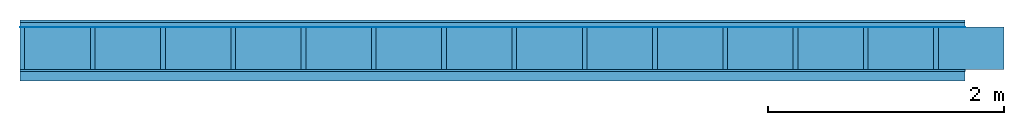
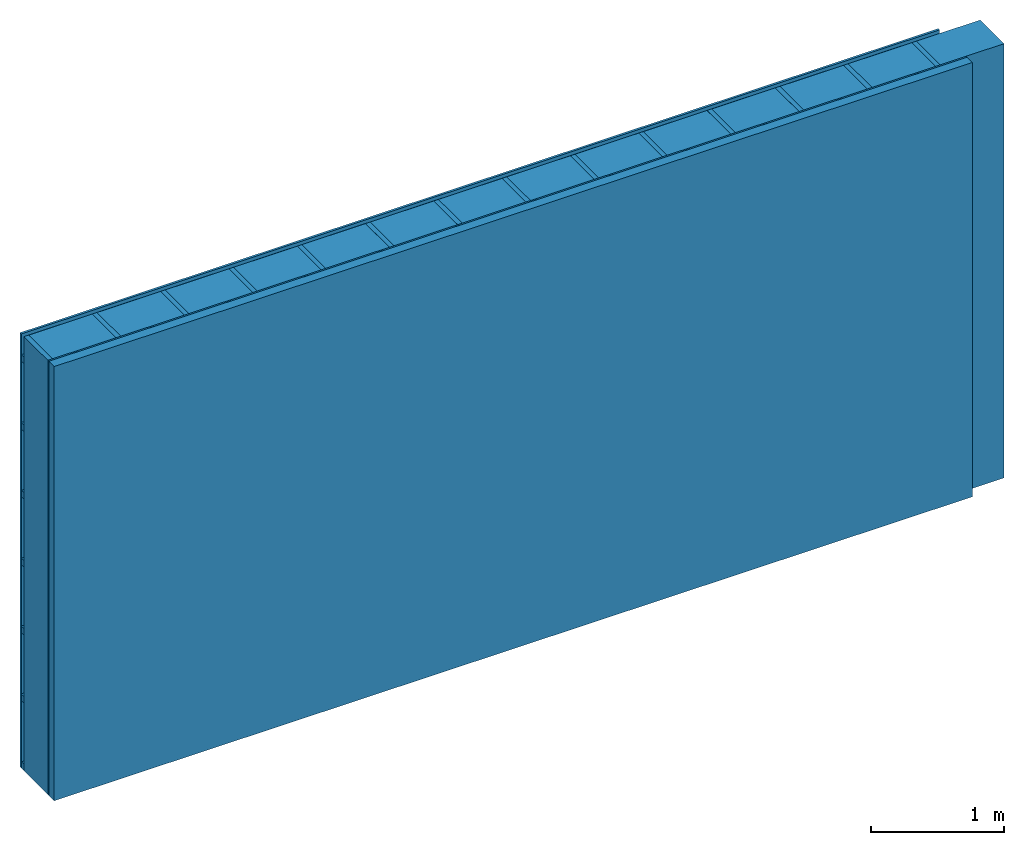
# One storey: 4 plates, 3 members, 1 element without a shape of its own.
"""IFC4 building model written with IfcOpenShell, lengths in metres."""

from ifc_helpers import new_model, si_unit, derived_unit, direction, frame, frame_2d, origin, origin_with_axes, place, context, project, spatial, rectangle, extrude, material, layer, layer_set, type_object, element, aggregate, save


model = new_model("IFC4")

# Units and contexts
plan_context = context("Plan", 3, precision=1e-05, world=origin(), true_north=direction((0.0, 1.0)))
model_context = context("Model", 3, precision=1e-05, world=origin(), true_north=direction((0.0, 1.0)))
ifc_project = project(units=[si_unit("LENGTHUNIT", "METRE"), derived_unit("SOUNDPRESSUREUNIT", [(si_unit("PRESSUREUNIT", "PASCAL", prefix="MICRO"), 0)]), si_unit("ENERGYUNIT", "JOULE", prefix="MEGA"), si_unit("MASSUNIT", "GRAM", prefix="KILO"), derived_unit("THERMALTRANSMITTANCEUNIT", [(si_unit("POWERUNIT", "WATT"), 1), (si_unit("AREAUNIT", "SQUARE_METRE"), -1), (si_unit("THERMODYNAMICTEMPERATUREUNIT", "KELVIN"), -1)]), derived_unit("AREADENSITYUNIT", [(si_unit("MASSUNIT", "GRAM", prefix="KILO"), 1), (si_unit("AREAUNIT", "SQUARE_METRE"), -1)]), derived_unit("USERDEFINED", [(si_unit("ENERGYUNIT", "JOULE", prefix="MEGA"), 1), (si_unit("AREAUNIT", "SQUARE_METRE"), -1)])], contexts=[plan_context, model_context])

# Site, building, storey
site = spatial("IfcSite", under=ifc_project)
building_placement = place(None, origin())
building = spatial("IfcBuilding", under=site, at=building_placement)
storey_placement = place(building_placement, origin())
storey = spatial("IfcBuildingStorey", under=building, at=storey_placement)

# Wall, members, plates
ifc_material_1 = material(Name="Wood cladding horizontal, closed")
ifc_layer_1 = layer(ifc_material_1, 0.02, Name="Cover 1st layer")
ifc_layer_2 = layer(None, 0.04, Name="Battens / profiles (ventilation)")
ifc_material_2 = material(Name="Vapor-permeable water barrier", Category="09.006")
ifc_layer_3 = layer(ifc_material_2, 0.0005, Name="outside 1st layer")
ifc_material_3 = material(Name="of the art")
ifc_layer_4 = layer(ifc_material_3, 0.0, Name="Bond")
ifc_layer_5 = layer(None, 0.36, Name="Support")
ifc_layer_6 = layer(ifc_material_3, 0.0, Name="Bond")
ifc_material_4 = material(Name="OSB panel", Category="07.013")
ifc_layer_7 = layer(ifc_material_4, 0.015, Name="1st layer")
ifc_material_5 = material(Name="Solid timber panel")
ifc_layer_8 = layer(ifc_material_5, 0.08, Name="Covering 1st layer")
ifc_layer_set = layer_set([ifc_layer_1, ifc_layer_2, ifc_layer_3, ifc_layer_4, ifc_layer_5, ifc_layer_6, ifc_layer_7, ifc_layer_8])
wall_type = type_object("IfcWallType", Name="D0963", PredefinedType="NOTDEFINED", material=ifc_layer_set)
wall_placement = place(None, frame((0.0, 0.0, 0.0), z_axis=(0.0, -1.0, 0.0), x_axis=(1.0, 0.0, 0.0)))
wall = element("IfcWall", 1, at=wall_placement, inside=storey, type_object=wall_type, material=ifc_layer_set, Name="Wall #1")
ifc_material_6 = material()
member_1_placement = place(wall_placement, origin())
member_1 = element("IfcMember", 2, at=member_1_placement, material=ifc_material_6, Name="Battens / profiles (ventilation)", context=plan_context, shape_type="SweptSolid", body=[
    extrude(rectangle(XDim=0.06, YDim=0.04, at=frame_2d((0.03, 0.02), x_axis=(1.0, 0.0))), frame((0.0, 0.0, 0.02), z_axis=(1.0, 0.0, 0.0), x_axis=(0.0, 1.0, 0.0)), (0.0, 0.0, 1.0), 8.0),
    extrude(rectangle(XDim=0.06, YDim=0.04, at=frame_2d((0.03, 0.02), x_axis=(1.0, 0.0))), frame((0.0, 0.625, 0.02), z_axis=(1.0, 0.0, 0.0), x_axis=(0.0, 1.0, 0.0)), (0.0, 0.0, 1.0), 8.0),
    extrude(rectangle(XDim=0.06, YDim=0.04, at=frame_2d((0.03, 0.02), x_axis=(1.0, 0.0))), frame((0.0, 1.25, 0.02), z_axis=(1.0, 0.0, 0.0), x_axis=(0.0, 1.0, 0.0)), (0.0, 0.0, 1.0), 8.0),
    extrude(rectangle(XDim=0.06, YDim=0.04, at=frame_2d((0.03, 0.02), x_axis=(1.0, 0.0))), frame((0.0, 1.875, 0.02), z_axis=(1.0, 0.0, 0.0), x_axis=(0.0, 1.0, 0.0)), (0.0, 0.0, 1.0), 8.0),
    extrude(rectangle(XDim=0.06, YDim=0.04, at=frame_2d((0.03, 0.02), x_axis=(1.0, 0.0))), frame((0.0, 2.5, 0.02), z_axis=(1.0, 0.0, 0.0), x_axis=(0.0, 1.0, 0.0)), (0.0, 0.0, 1.0), 8.0),
    extrude(rectangle(XDim=0.06, YDim=0.04, at=frame_2d((0.03, 0.02), x_axis=(1.0, 0.0))), frame((0.0, 3.125, 0.02), z_axis=(1.0, 0.0, 0.0), x_axis=(0.0, 1.0, 0.0)), (0.0, 0.0, 1.0), 8.0),
    extrude(rectangle(XDim=0.06, YDim=0.04, at=frame_2d((0.03, 0.02), x_axis=(1.0, 0.0))), frame((0.0, 3.75, 0.02), z_axis=(1.0, 0.0, 0.0), x_axis=(0.0, 1.0, 0.0)), (0.0, 0.0, 1.0), 8.0),
])
ifc_material_7 = material()
member_2_placement = place(wall_placement, origin())
member_2 = element("IfcMember", 3, at=member_2_placement, material=ifc_material_7, Name="Support", context=plan_context, shape_type="SweptSolid", body=[
    extrude(rectangle(XDim=0.04, YDim=0.36, at=frame_2d((0.02, 0.18), x_axis=(1.0, 0.0))), frame((0.0, 4.0, 0.0605), z_axis=(0.0, -1.0, 0.0), x_axis=(1.0, 0.0, 0.0)), (0.0, 0.0, 1.0), 4.0),
    extrude(rectangle(XDim=0.04, YDim=0.36, at=frame_2d((0.02, 0.18), x_axis=(1.0, 0.0))), frame((0.595, 4.0, 0.0605), z_axis=(0.0, -1.0, 0.0), x_axis=(1.0, 0.0, 0.0)), (0.0, 0.0, 1.0), 4.0),
    extrude(rectangle(XDim=0.04, YDim=0.36, at=frame_2d((0.02, 0.18), x_axis=(1.0, 0.0))), frame((1.19, 4.0, 0.0605), z_axis=(0.0, -1.0, 0.0), x_axis=(1.0, 0.0, 0.0)), (0.0, 0.0, 1.0), 4.0),
    extrude(rectangle(XDim=0.04, YDim=0.36, at=frame_2d((0.02, 0.18), x_axis=(1.0, 0.0))), frame((1.785, 4.0, 0.0605), z_axis=(0.0, -1.0, 0.0), x_axis=(1.0, 0.0, 0.0)), (0.0, 0.0, 1.0), 4.0),
    extrude(rectangle(XDim=0.04, YDim=0.36, at=frame_2d((0.02, 0.18), x_axis=(1.0, 0.0))), frame((2.38, 4.0, 0.0605), z_axis=(0.0, -1.0, 0.0), x_axis=(1.0, 0.0, 0.0)), (0.0, 0.0, 1.0), 4.0),
    extrude(rectangle(XDim=0.04, YDim=0.36, at=frame_2d((0.02, 0.18), x_axis=(1.0, 0.0))), frame((2.975, 4.0, 0.0605), z_axis=(0.0, -1.0, 0.0), x_axis=(1.0, 0.0, 0.0)), (0.0, 0.0, 1.0), 4.0),
    extrude(rectangle(XDim=0.04, YDim=0.36, at=frame_2d((0.02, 0.18), x_axis=(1.0, 0.0))), frame((3.57, 4.0, 0.0605), z_axis=(0.0, -1.0, 0.0), x_axis=(1.0, 0.0, 0.0)), (0.0, 0.0, 1.0), 4.0),
    extrude(rectangle(XDim=0.04, YDim=0.36, at=frame_2d((0.02, 0.18), x_axis=(1.0, 0.0))), frame((4.165, 4.0, 0.0605), z_axis=(0.0, -1.0, 0.0), x_axis=(1.0, 0.0, 0.0)), (0.0, 0.0, 1.0), 4.0),
    extrude(rectangle(XDim=0.04, YDim=0.36, at=frame_2d((0.02, 0.18), x_axis=(1.0, 0.0))), frame((4.76, 4.0, 0.0605), z_axis=(0.0, -1.0, 0.0), x_axis=(1.0, 0.0, 0.0)), (0.0, 0.0, 1.0), 4.0),
    extrude(rectangle(XDim=0.04, YDim=0.36, at=frame_2d((0.02, 0.18), x_axis=(1.0, 0.0))), frame((5.355, 4.0, 0.0605), z_axis=(0.0, -1.0, 0.0), x_axis=(1.0, 0.0, 0.0)), (0.0, 0.0, 1.0), 4.0),
    extrude(rectangle(XDim=0.04, YDim=0.36, at=frame_2d((0.02, 0.18), x_axis=(1.0, 0.0))), frame((5.95, 4.0, 0.0605), z_axis=(0.0, -1.0, 0.0), x_axis=(1.0, 0.0, 0.0)), (0.0, 0.0, 1.0), 4.0),
    extrude(rectangle(XDim=0.04, YDim=0.36, at=frame_2d((0.02, 0.18), x_axis=(1.0, 0.0))), frame((6.545, 4.0, 0.0605), z_axis=(0.0, -1.0, 0.0), x_axis=(1.0, 0.0, 0.0)), (0.0, 0.0, 1.0), 4.0),
    extrude(rectangle(XDim=0.04, YDim=0.36, at=frame_2d((0.02, 0.18), x_axis=(1.0, 0.0))), frame((7.14, 4.0, 0.0605), z_axis=(0.0, -1.0, 0.0), x_axis=(1.0, 0.0, 0.0)), (0.0, 0.0, 1.0), 4.0),
    extrude(rectangle(XDim=0.04, YDim=0.36, at=frame_2d((0.02, 0.18), x_axis=(1.0, 0.0))), frame((7.735, 4.0, 0.0605), z_axis=(0.0, -1.0, 0.0), x_axis=(1.0, 0.0, 0.0)), (0.0, 0.0, 1.0), 4.0),
])
ifc_material_8 = material(Name="Mineral wool")
member_3_placement = place(wall_placement, origin())
member_3 = element("IfcMember", 4, at=member_3_placement, material=ifc_material_8, Name="Cavity", context=plan_context, shape_type="SweptSolid", body=[
    extrude(rectangle(XDim=0.555, YDim=0.36, at=frame_2d((0.2775, 0.18), x_axis=(1.0, 0.0))), frame((0.04, 4.0, 0.0605), z_axis=(0.0, -1.0, 0.0), x_axis=(1.0, 0.0, 0.0)), (0.0, 0.0, 1.0), 4.0),
    extrude(rectangle(XDim=0.555, YDim=0.36, at=frame_2d((0.2775, 0.18), x_axis=(1.0, 0.0))), frame((0.635, 4.0, 0.0605), z_axis=(0.0, -1.0, 0.0), x_axis=(1.0, 0.0, 0.0)), (0.0, 0.0, 1.0), 4.0),
    extrude(rectangle(XDim=0.555, YDim=0.36, at=frame_2d((0.2775, 0.18), x_axis=(1.0, 0.0))), frame((1.23, 4.0, 0.0605), z_axis=(0.0, -1.0, 0.0), x_axis=(1.0, 0.0, 0.0)), (0.0, 0.0, 1.0), 4.0),
    extrude(rectangle(XDim=0.555, YDim=0.36, at=frame_2d((0.2775, 0.18), x_axis=(1.0, 0.0))), frame((1.825, 4.0, 0.0605), z_axis=(0.0, -1.0, 0.0), x_axis=(1.0, 0.0, 0.0)), (0.0, 0.0, 1.0), 4.0),
    extrude(rectangle(XDim=0.555, YDim=0.36, at=frame_2d((0.2775, 0.18), x_axis=(1.0, 0.0))), frame((2.42, 4.0, 0.0605), z_axis=(0.0, -1.0, 0.0), x_axis=(1.0, 0.0, 0.0)), (0.0, 0.0, 1.0), 4.0),
    extrude(rectangle(XDim=0.555, YDim=0.36, at=frame_2d((0.2775, 0.18), x_axis=(1.0, 0.0))), frame((3.015, 4.0, 0.0605), z_axis=(0.0, -1.0, 0.0), x_axis=(1.0, 0.0, 0.0)), (0.0, 0.0, 1.0), 4.0),
    extrude(rectangle(XDim=0.555, YDim=0.36, at=frame_2d((0.2775, 0.18), x_axis=(1.0, 0.0))), frame((3.61, 4.0, 0.0605), z_axis=(0.0, -1.0, 0.0), x_axis=(1.0, 0.0, 0.0)), (0.0, 0.0, 1.0), 4.0),
    extrude(rectangle(XDim=0.555, YDim=0.36, at=frame_2d((0.2775, 0.18), x_axis=(1.0, 0.0))), frame((4.205, 4.0, 0.0605), z_axis=(0.0, -1.0, 0.0), x_axis=(1.0, 0.0, 0.0)), (0.0, 0.0, 1.0), 4.0),
    extrude(rectangle(XDim=0.555, YDim=0.36, at=frame_2d((0.2775, 0.18), x_axis=(1.0, 0.0))), frame((4.8, 4.0, 0.0605), z_axis=(0.0, -1.0, 0.0), x_axis=(1.0, 0.0, 0.0)), (0.0, 0.0, 1.0), 4.0),
    extrude(rectangle(XDim=0.555, YDim=0.36, at=frame_2d((0.2775, 0.18), x_axis=(1.0, 0.0))), frame((5.395, 4.0, 0.0605), z_axis=(0.0, -1.0, 0.0), x_axis=(1.0, 0.0, 0.0)), (0.0, 0.0, 1.0), 4.0),
    extrude(rectangle(XDim=0.555, YDim=0.36, at=frame_2d((0.2775, 0.18), x_axis=(1.0, 0.0))), frame((5.99, 4.0, 0.0605), z_axis=(0.0, -1.0, 0.0), x_axis=(1.0, 0.0, 0.0)), (0.0, 0.0, 1.0), 4.0),
    extrude(rectangle(XDim=0.555, YDim=0.36, at=frame_2d((0.2775, 0.18), x_axis=(1.0, 0.0))), frame((6.585, 4.0, 0.0605), z_axis=(0.0, -1.0, 0.0), x_axis=(1.0, 0.0, 0.0)), (0.0, 0.0, 1.0), 4.0),
    extrude(rectangle(XDim=0.555, YDim=0.36, at=frame_2d((0.2775, 0.18), x_axis=(1.0, 0.0))), frame((7.18, 4.0, 0.0605), z_axis=(0.0, -1.0, 0.0), x_axis=(1.0, 0.0, 0.0)), (0.0, 0.0, 1.0), 4.0),
    extrude(rectangle(XDim=0.555, YDim=0.36, at=frame_2d((0.2775, 0.18), x_axis=(1.0, 0.0))), frame((7.775, 4.0, 0.0605), z_axis=(0.0, -1.0, 0.0), x_axis=(1.0, 0.0, 0.0)), (0.0, 0.0, 1.0), 4.0),
])
plate_1_placement = place(wall_placement, origin())
plate_1 = element("IfcPlate", 5, at=plate_1_placement, material=ifc_material_1, Name="Cover 1st layer", context=plan_context, shape_type="SweptSolid", body=[
    extrude(rectangle(XDim=8.0, YDim=4.0, at=frame_2d((4.0, 2.0), x_axis=(1.0, 0.0))), origin_with_axes(), (0.0, 0.0, 1.0), 0.02),
])
plate_2_placement = place(wall_placement, origin())
plate_2 = element("IfcPlate", 6, at=plate_2_placement, material=ifc_material_2, Name="outside 1st layer", context=plan_context, shape_type="SweptSolid", body=[
    extrude(rectangle(XDim=8.0, YDim=4.0, at=frame_2d((4.0, 2.0), x_axis=(1.0, 0.0))), frame((0.0, 0.0, 0.06), z_axis=(0.0, 0.0, 1.0), x_axis=(1.0, 0.0, 0.0)), (0.0, 0.0, 1.0), 0.0005),
])
plate_3_placement = place(wall_placement, origin())
plate_3 = element("IfcPlate", 7, at=plate_3_placement, material=ifc_material_4, Name="1st layer", context=plan_context, shape_type="SweptSolid", body=[
    extrude(rectangle(XDim=8.0, YDim=4.0, at=frame_2d((4.0, 2.0), x_axis=(1.0, 0.0))), frame((0.0, 0.0, 0.4205), z_axis=(0.0, 0.0, 1.0), x_axis=(1.0, 0.0, 0.0)), (0.0, 0.0, 1.0), 0.015),
])
plate_4_placement = place(wall_placement, origin())
plate_4 = element("IfcPlate", 8, at=plate_4_placement, material=ifc_material_5, Name="Covering 1st layer", context=plan_context, shape_type="SweptSolid", body=[
    extrude(rectangle(XDim=8.0, YDim=4.0, at=frame_2d((4.0, 2.0), x_axis=(1.0, 0.0))), frame((0.0, 0.0, 0.4355), z_axis=(0.0, 0.0, 1.0), x_axis=(1.0, 0.0, 0.0)), (0.0, 0.0, 1.0), 0.08),
])
aggregate(wall, [plate_1, member_1, plate_2, member_2, member_3, plate_3, plate_4])

save(model, "model.ifc")
